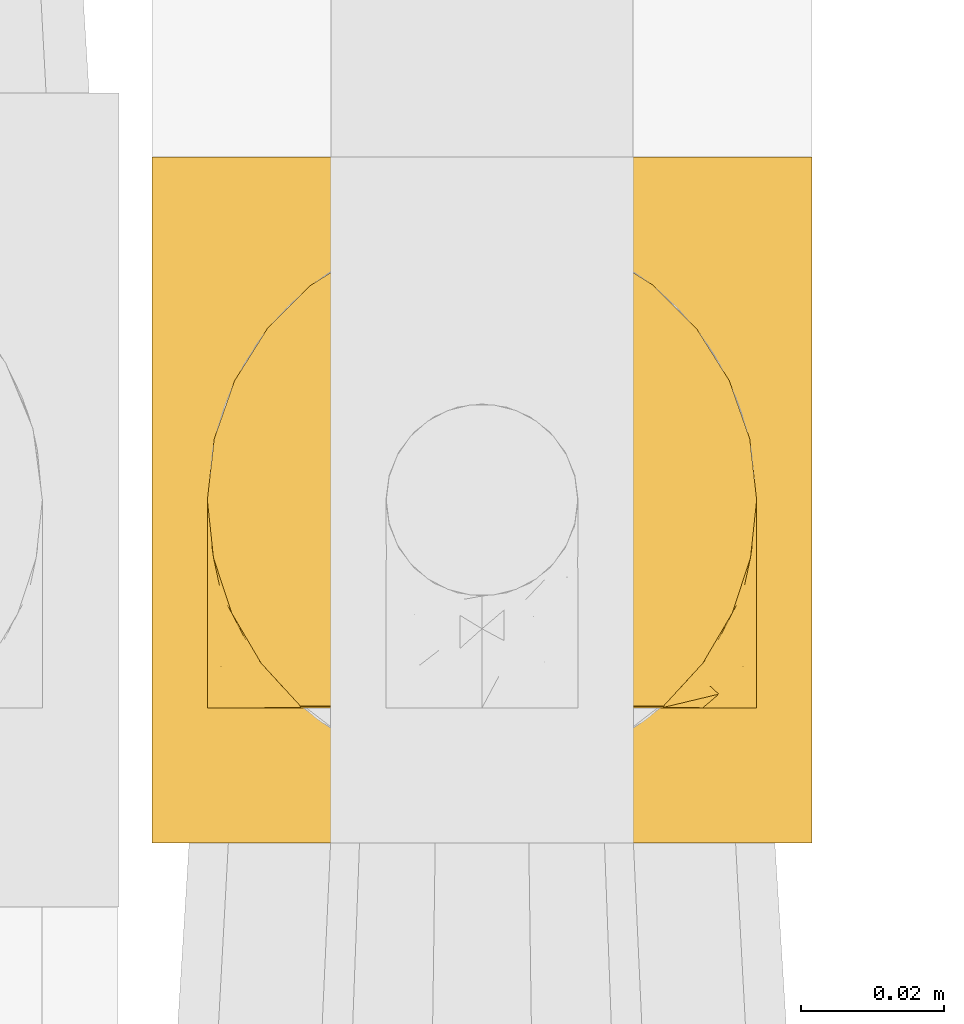
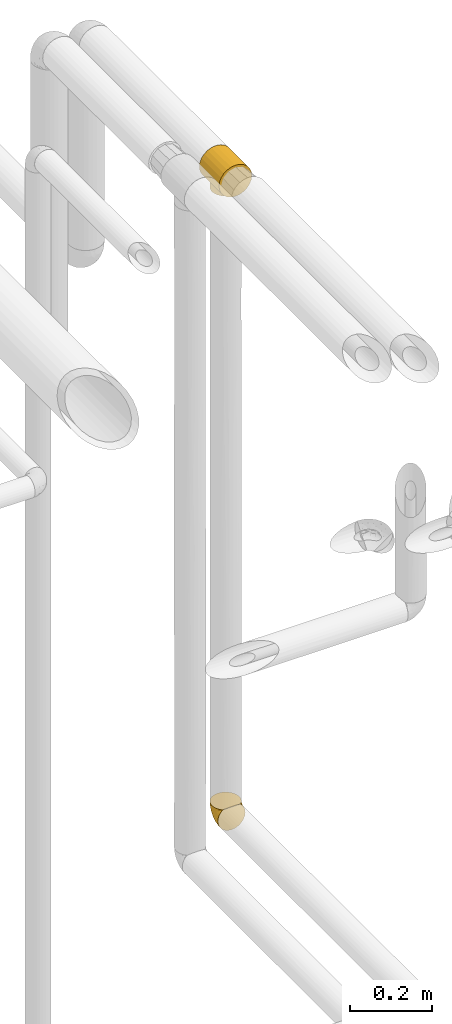
# One storey, part 508 of 827: 2 coverings.
"""IFC2X3 building model written with IfcOpenShell, lengths in millimetres."""

from ifc_helpers import new_model, entity, si_unit, converted_unit, derived_unit, direction, frame, origin, place, context, subcontext, project, spatial, faceted_brep, element, save


model = new_model("IFC2X3")

# Units and contexts
model_context = context("Model", 3, precision=0.01, world=origin(), true_north=direction((6.12303176911189e-17, 1.0)))
body_context = subcontext(model_context, "Body", "Model", "MODEL_VIEW")
ifc_project = project(units=[si_unit("LENGTHUNIT", "METRE", prefix="MILLI"), si_unit("AREAUNIT", "SQUARE_METRE"), si_unit("VOLUMEUNIT", "CUBIC_METRE"), converted_unit("PLANEANGLEUNIT", "DEGREE", entity("IfcRatioMeasure", 0.0174532925199433), si_unit("PLANEANGLEUNIT", "RADIAN"), dimensions=[0, 0, 0, 0, 0, 0, 0]), si_unit("MASSUNIT", "GRAM", prefix="KILO"), derived_unit("MASSDENSITYUNIT", [(si_unit("MASSUNIT", "GRAM", prefix="KILO"), 1), (si_unit("LENGTHUNIT", "METRE"), -3)]), derived_unit("MOMENTOFINERTIAUNIT", [(si_unit("LENGTHUNIT", "METRE"), 4)]), si_unit("TIMEUNIT", "SECOND"), si_unit("FREQUENCYUNIT", "HERTZ"), si_unit("THERMODYNAMICTEMPERATUREUNIT", "DEGREE_CELSIUS"), derived_unit("THERMALTRANSMITTANCEUNIT", [(si_unit("MASSUNIT", "GRAM", prefix="KILO"), 1), (si_unit("THERMODYNAMICTEMPERATUREUNIT", "KELVIN"), -1), (si_unit("TIMEUNIT", "SECOND"), -3)]), derived_unit("VOLUMETRICFLOWRATEUNIT", [(si_unit("LENGTHUNIT", "METRE"), 3), (si_unit("TIMEUNIT", "SECOND"), -1)]), derived_unit("MASSFLOWRATEUNIT", [(si_unit("MASSUNIT", "GRAM", prefix="KILO"), 1), (si_unit("TIMEUNIT", "SECOND"), -1)]), derived_unit("ROTATIONALFREQUENCYUNIT", [(si_unit("TIMEUNIT", "SECOND"), -1)]), si_unit("ELECTRICCURRENTUNIT", "AMPERE"), si_unit("ELECTRICVOLTAGEUNIT", "VOLT"), si_unit("POWERUNIT", "WATT"), si_unit("FORCEUNIT", "NEWTON", prefix="KILO"), si_unit("ILLUMINANCEUNIT", "LUX"), si_unit("LUMINOUSFLUXUNIT", "LUMEN"), si_unit("LUMINOUSINTENSITYUNIT", "CANDELA"), derived_unit("USERDEFINED", [(si_unit("MASSUNIT", "GRAM", prefix="KILO"), -1), (si_unit("LENGTHUNIT", "METRE"), -2), (si_unit("TIMEUNIT", "SECOND"), 3), (si_unit("LUMINOUSFLUXUNIT", "LUMEN"), 1)]), derived_unit("LINEARVELOCITYUNIT", [(si_unit("LENGTHUNIT", "METRE"), 1), (si_unit("TIMEUNIT", "SECOND"), -1)]), si_unit("PRESSUREUNIT", "PASCAL"), derived_unit("USERDEFINED", [(si_unit("LENGTHUNIT", "METRE"), -2), (si_unit("MASSUNIT", "GRAM", prefix="KILO"), 1), (si_unit("TIMEUNIT", "SECOND"), -2)]), derived_unit("LINEARFORCEUNIT", [(si_unit("MASSUNIT", "GRAM", prefix="KILO"), 1), (si_unit("LENGTHUNIT", "METRE"), 1), (si_unit("TIMEUNIT", "SECOND"), -2), (si_unit("LENGTHUNIT", "METRE"), -1)]), derived_unit("PLANARFORCEUNIT", [(si_unit("MASSUNIT", "GRAM", prefix="KILO"), 1), (si_unit("LENGTHUNIT", "METRE"), 1), (si_unit("TIMEUNIT", "SECOND"), -2), (si_unit("LENGTHUNIT", "METRE"), -2)])], contexts=[model_context])

# Site, building, storey
site_placement = place(None, origin())
site = spatial("IfcSite", under=ifc_project, at=site_placement, CompositionType="ELEMENT")
building_placement = place(site_placement, origin())
building = spatial("IfcBuilding", under=site, at=building_placement, CompositionType="ELEMENT")
storey_placement = place(building_placement, frame((0.0, 0.0, 28200.0)))
storey = spatial("IfcBuildingStorey", under=building, at=storey_placement, Name="08", CompositionType="ELEMENT", Elevation=28200.0)

# Coverings
covering_1_placement = place(storey_placement, frame((61104.84, 17404.83, 2951.74)))
element("IfcCovering", 1, at=covering_1_placement, inside=storey, Name=":ADSK_", ObjectType=":ADSK_", PredefinedType="INSULATION", context=body_context, shape_type="Brep", body=[
    faceted_brep([(24.7, 96.0, 88.01), (35.84, 96.0, 92.63), (47.8, 96.0, 94.2), (59.75, 96.0, 92.63), (70.9, 96.0, 88.01), (80.46, 96.0, 80.67), (87.81, 96.0, 71.1), (92.42, 96.0, 59.96), (94.0, 96.0, 48.0), (92.42, 96.0, 36.04), (87.81, 96.0, 24.9), (80.46, 96.0, 15.33), (75.68, 96.0, 11.66), (70.9, 96.0, 7.99), (68.11, 96.0, 6.84), (65.32, 96.0, 5.68), (62.54, 96.0, 4.53), (59.75, 96.0, 3.37), (56.76, 96.0, 2.98), (53.77, 96.0, 2.59), (50.78, 96.0, 2.19), (47.8, 96.0, 1.8), (44.81, 96.0, 2.19), (41.82, 96.0, 2.59), (38.83, 96.0, 2.98), (35.84, 96.0, 3.37), (33.05, 96.0, 4.53), (30.27, 96.0, 5.68), (27.48, 96.0, 6.84), (24.7, 96.0, 7.99), (19.91, 96.0, 11.66), (15.13, 96.0, 15.33), (7.78, 96.0, 24.9), (3.17, 96.0, 36.04), (1.6, 96.0, 48.0), (3.17, 96.0, 59.96), (7.78, 96.0, 71.1), (15.13, 96.0, 80.67), (94.0, 0.0, 48.0), (92.42, 0.0, 59.96), (87.81, 0.0, 71.1), (80.46, 0.0, 80.67), (70.9, 0.0, 88.01), (59.75, 0.0, 92.63), (47.8, 0.0, 94.2), (35.84, 0.0, 92.63), (24.7, 0.0, 88.01), (15.13, 0.0, 80.67), (7.78, 0.0, 71.1), (3.17, 0.0, 59.96), (1.6, 0.0, 48.0), (3.17, 0.0, 36.04), (7.78, 0.0, 24.9), (15.13, 0.0, 15.33), (19.91, 0.0, 11.66), (24.7, 0.0, 7.99), (27.48, 0.0, 6.84), (30.27, 0.0, 5.68), (33.05, 0.0, 4.53), (35.84, 0.0, 3.37), (38.83, 0.0, 2.98), (41.82, 0.0, 2.59), (44.81, 0.0, 2.19), (47.8, 0.0, 1.8), (50.78, 0.0, 2.19), (53.77, 0.0, 2.59), (56.76, 0.0, 2.98), (59.75, 0.0, 3.37), (62.54, 0.0, 4.53), (65.32, 0.0, 5.68), (68.11, 0.0, 6.84), (70.9, 0.0, 7.99), (75.68, 0.0, 11.66), (80.46, 0.0, 15.33), (87.81, 0.0, 24.9), (92.42, 0.0, 36.04), (86.25, 48.0, 22.39), (77.97, 24.17, 13.02), (82.31, 31.06, 17.29), (72.25, 18.33, 8.81), (65.18, 82.3, 5.19), (61.03, 83.83, 3.95), (85.18, 39.03, 20.86), (68.72, 16.02, 7.0), (52.34, 10.09, 2.25), (54.61, 10.37, 2.48), (82.31, 64.94, 17.29), (85.18, 56.97, 20.86), (50.07, 86.18, 2.03), (77.97, 71.83, 13.02), (72.25, 77.67, 8.81), (68.72, 79.98, 7.0), (65.18, 13.7, 5.19), (61.03, 12.17, 3.95), (50.07, 9.82, 2.03), (47.8, 86.45, 1.8), (47.8, 9.55, 1.8), (56.88, 10.64, 2.7), (58.95, 84.6, 3.32), (58.95, 11.4, 3.32), (52.34, 85.91, 2.25), (54.61, 85.63, 2.48), (56.88, 85.36, 2.7), (43.25, 10.09, 2.25), (36.64, 11.4, 3.32), (34.56, 12.17, 3.95), (26.87, 16.02, 7.0), (36.64, 84.6, 3.32), (38.71, 85.36, 2.7), (30.41, 13.7, 5.19), (23.34, 18.33, 8.81), (38.71, 10.64, 2.7), (40.98, 85.63, 2.48), (45.52, 86.18, 2.03), (43.25, 85.91, 2.25), (40.98, 10.37, 2.48), (26.87, 79.98, 7.0), (23.34, 77.67, 8.81), (17.62, 24.17, 13.02), (34.56, 83.83, 3.95), (17.62, 71.83, 13.02), (30.41, 82.3, 5.19), (45.52, 9.82, 2.03), (13.28, 31.06, 17.29), (9.35, 48.0, 22.39), (10.41, 39.03, 20.86), (13.28, 64.94, 17.29), (10.41, 56.97, 20.86), (86.25, 48.0, 0.0), (84.94, 38.05, 0.0), (81.09, 28.77, 0.0), (74.98, 20.81, 0.0), (67.02, 14.7, 0.0), (62.38, 12.78, 0.0), (57.75, 10.86, 0.0), (55.26, 10.53, 0.0), (52.77, 10.21, 0.0), (50.28, 9.88, 0.0), (47.8, 9.55, 0.0), (45.31, 9.88, 0.0), (42.82, 10.21, 0.0), (40.33, 10.53, 0.0), (37.84, 10.86, 0.0), (33.21, 12.78, 0.0), (28.57, 14.7, 0.0), (20.61, 20.81, 0.0), (14.5, 28.77, 0.0), (10.66, 38.05, 0.0), (9.35, 48.0, 0.0), (10.66, 57.95, 0.0), (14.5, 67.22, 0.0), (20.61, 75.19, 0.0), (28.57, 81.3, 0.0), (33.21, 83.22, 0.0), (37.84, 85.14, 0.0), (40.33, 85.47, 0.0), (42.82, 85.79, 0.0), (45.31, 86.12, 0.0), (47.8, 86.45, 0.0), (50.28, 86.12, 0.0), (52.77, 85.79, 0.0), (55.26, 85.47, 0.0), (57.75, 85.14, 0.0), (62.38, 83.22, 0.0), (67.02, 81.3, 0.0), (74.98, 75.19, 0.0), (81.09, 67.22, 0.0), (84.94, 57.95, 0.0)], [[[0, 1, 2, 3, 4, 5, 6, 7, 8, 9, 10, 11, 12, 13, 14, 15, 16, 17, 18, 19, 20, 21, 22, 23, 24, 25, 26, 27, 28, 29, 30, 31, 32, 33, 34, 35, 36, 37]], [[38, 39, 40, 41, 42, 43, 44, 45, 46, 47, 48, 49, 50, 51, 52, 53, 54, 55, 56, 57, 58, 59, 60, 61, 62, 63, 64, 65, 66, 67, 68, 69, 70, 71, 72, 73, 74, 75]], [[42, 41, 5, 4]], [[2, 44, 43, 3]], [[43, 42, 4, 3]], [[6, 40, 39, 7]], [[7, 39, 38, 8]], [[5, 41, 40, 6]], [[75, 9, 8, 38]], [[74, 76, 75]], [[73, 77, 78]], [[72, 71, 79]], [[16, 80, 81]], [[82, 74, 78]], [[77, 73, 72]], [[78, 74, 73]], [[82, 76, 74]], [[9, 76, 10]], [[83, 71, 70]], [[65, 84, 85]], [[86, 10, 87]], [[88, 21, 20]], [[11, 10, 86]], [[89, 11, 86]], [[90, 12, 89]], [[87, 10, 76]], [[75, 76, 9]], [[80, 14, 91]], [[70, 92, 83]], [[92, 68, 93]], [[79, 71, 83]], [[66, 65, 85]], [[68, 67, 93]], [[92, 70, 69, 68]], [[84, 64, 94]], [[21, 88, 95]], [[94, 63, 96]], [[80, 16, 15, 14]], [[66, 85, 97]], [[17, 81, 98]], [[63, 94, 64]], [[99, 66, 97]], [[90, 13, 12]], [[67, 99, 93]], [[91, 14, 13]], [[13, 90, 91]], [[89, 12, 11]], [[20, 19, 100]], [[101, 18, 102]], [[18, 101, 19]], [[17, 98, 18]], [[18, 98, 102]], [[66, 99, 67]], [[19, 101, 100]], [[84, 65, 64]], [[77, 72, 79]], [[20, 100, 88]], [[81, 17, 16]], [[61, 103, 62]], [[60, 59, 104]], [[105, 59, 58]], [[55, 106, 56]], [[107, 24, 108]], [[57, 56, 109, 58]], [[54, 110, 55]], [[104, 111, 60]], [[58, 109, 105]], [[24, 112, 108]], [[24, 107, 25]], [[22, 113, 114]], [[115, 60, 111]], [[116, 117, 29]], [[110, 54, 118]], [[116, 29, 28]], [[25, 119, 26]], [[120, 30, 117]], [[26, 121, 28, 27]], [[122, 63, 62]], [[109, 56, 106]], [[59, 105, 104]], [[118, 53, 123]], [[53, 118, 54]], [[123, 53, 52]], [[124, 52, 51]], [[63, 122, 96]], [[113, 21, 95]], [[124, 125, 52]], [[52, 125, 123]], [[51, 50, 34, 33]], [[114, 23, 22]], [[21, 113, 22]], [[24, 23, 112]], [[31, 126, 32]], [[28, 121, 116]], [[30, 29, 117]], [[31, 120, 126]], [[126, 127, 32]], [[25, 107, 119]], [[124, 32, 127]], [[32, 124, 33]], [[60, 115, 61]], [[33, 124, 51]], [[121, 26, 119]], [[120, 31, 30]], [[23, 114, 112]], [[55, 110, 106]], [[62, 103, 122]], [[61, 115, 103]], [[35, 49, 48, 36]], [[36, 48, 47, 37]], [[50, 49, 35, 34]], [[0, 46, 45, 1]], [[1, 45, 44, 2]], [[37, 47, 46, 0]], [[128, 129, 130, 131, 132, 133, 134, 135, 136, 137, 138, 139, 140, 141, 142, 143, 144, 145, 146, 147, 148, 149, 150, 151, 152, 153, 154, 155, 156, 157, 158, 159, 160, 161, 162, 163, 164, 165, 166, 167]], [[97, 135, 134]], [[92, 133, 132]], [[94, 138, 137]], [[137, 136, 84]], [[134, 93, 99, 97]], [[132, 79, 83, 92]], [[133, 93, 134]], [[133, 92, 93]], [[132, 131, 79]], [[137, 84, 94]], [[77, 131, 130]], [[138, 94, 96]], [[129, 128, 82]], [[85, 136, 135]], [[78, 130, 129]], [[136, 85, 84]], [[77, 130, 78]], [[82, 78, 129]], [[76, 82, 128]], [[135, 97, 85]], [[131, 77, 79]], [[87, 128, 167]], [[86, 167, 166]], [[160, 101, 161]], [[76, 128, 87]], [[102, 162, 161]], [[87, 167, 86]], [[166, 89, 86]], [[88, 158, 95]], [[166, 165, 89]], [[90, 165, 164]], [[162, 102, 98, 81]], [[159, 88, 100]], [[160, 100, 101]], [[164, 80, 91, 90]], [[80, 164, 163]], [[161, 101, 102]], [[163, 81, 80]], [[162, 81, 163]], [[158, 88, 159]], [[165, 90, 89]], [[100, 160, 159]], [[108, 155, 154]], [[121, 153, 152]], [[113, 158, 157]], [[157, 156, 114]], [[154, 119, 107, 108]], [[152, 117, 116, 121]], [[153, 119, 154]], [[153, 121, 119]], [[152, 151, 117]], [[155, 108, 112]], [[120, 151, 150]], [[150, 149, 126]], [[148, 127, 149]], [[156, 112, 114]], [[120, 150, 126]], [[157, 114, 113]], [[127, 126, 149]], [[124, 127, 148]], [[112, 156, 155]], [[151, 120, 117]], [[158, 113, 95]], [[125, 148, 147]], [[123, 147, 146]], [[140, 115, 141]], [[124, 148, 125]], [[111, 142, 141]], [[125, 147, 123]], [[146, 118, 123]], [[122, 138, 96]], [[146, 145, 118]], [[110, 145, 144]], [[142, 111, 104, 105]], [[139, 122, 103]], [[140, 103, 115]], [[144, 109, 106, 110]], [[109, 144, 143]], [[141, 115, 111]], [[143, 105, 109]], [[142, 105, 143]], [[138, 122, 139]], [[145, 110, 118]], [[103, 140, 139]]]),
])
covering_2_placement = place(storey_placement, frame((61112.59, 17422.14, 1059.95)))
element("IfcCovering", 2, at=covering_2_placement, inside=storey, Name=":ADSK_", ObjectType=":ADSK_", PredefinedType="INSULATION", context=body_context, shape_type="Brep", body=[
    faceted_brep([(74.68, 47.38, 69.15), (70.1, 54.67, 69.15), (64.01, 60.76, 69.15), (56.72, 65.34, 69.15), (48.6, 68.18, 69.15), (40.05, 69.15, 69.15), (31.49, 68.18, 69.15), (23.36, 65.33, 69.15), (16.07, 60.75, 69.15), (9.98, 54.66, 69.15), (5.4, 47.37, 69.15), (2.56, 39.25, 69.15), (1.6, 30.7, 69.15), (2.46, 22.59, 69.15), (5.01, 14.86, 69.15), (9.13, 7.84, 69.15), (14.62, 1.85, 69.15), (16.82, 1.85, 69.15), (18.56, 1.85, 69.15), (20.52, 1.85, 69.15), (22.49, 1.85, 69.15), (24.46, 1.85, 69.15), (26.42, 1.85, 69.15), (28.39, 1.85, 69.15), (30.36, 1.85, 69.15), (32.55, 1.85, 69.15), (34.75, 1.85, 69.15), (36.94, 1.85, 69.15), (39.13, 1.85, 69.15), (41.33, 1.85, 69.15), (43.52, 1.85, 69.15), (45.72, 1.85, 69.15), (47.91, 1.85, 69.15), (50.11, 1.85, 69.15), (52.3, 1.85, 69.15), (54.49, 1.85, 69.15), (56.69, 1.85, 69.15), (58.88, 1.85, 69.15), (61.08, 1.85, 69.15), (63.27, 1.85, 69.15), (65.47, 1.85, 69.15), (70.97, 7.85, 69.15), (75.09, 14.88, 69.15), (77.64, 22.61, 69.15), (78.5, 30.7, 69.15), (77.53, 39.26, 69.15), (14.62, 1.6, 68.89), (9.12, 1.6, 62.89), (5.0, 1.6, 55.87), (2.46, 1.6, 48.14), (1.6, 1.6, 40.05), (2.91, 1.6, 30.09), (6.75, 1.6, 20.82), (12.86, 1.6, 12.86), (20.82, 1.6, 6.75), (30.09, 1.6, 2.91), (40.05, 1.6, 1.6), (50.0, 1.6, 2.91), (59.27, 1.6, 6.75), (67.23, 1.6, 12.86), (73.34, 1.6, 20.82), (77.19, 1.6, 30.09), (78.5, 1.6, 40.05), (77.63, 1.6, 48.14), (75.09, 1.6, 55.87), (70.97, 1.6, 62.89), (65.47, 1.6, 68.89), (63.27, 1.6, 68.89), (62.29, 1.6, 68.89), (60.7, 1.6, 68.89), (59.11, 1.6, 68.89), (57.52, 1.6, 68.89), (55.93, 1.6, 68.89), (54.34, 1.6, 68.89), (52.76, 1.6, 68.89), (51.17, 1.6, 68.89), (49.58, 1.6, 68.89), (47.99, 1.6, 68.89), (46.4, 1.6, 68.89), (44.81, 1.6, 68.89), (43.22, 1.6, 68.89), (41.63, 1.6, 68.89), (40.05, 1.6, 68.89), (38.46, 1.6, 68.89), (36.87, 1.6, 68.89), (35.28, 1.6, 68.89), (33.69, 1.6, 68.89), (32.1, 1.6, 68.89), (30.51, 1.6, 68.89), (28.92, 1.6, 68.89), (27.33, 1.6, 68.89), (25.37, 1.6, 68.89), (23.4, 1.6, 68.89), (21.21, 1.6, 68.89), (19.01, 1.6, 68.89), (16.82, 1.6, 68.89), (42.32, 1.78, 68.97), (44.02, 1.77, 68.96), (47.13, 1.78, 68.97), (48.74, 1.77, 68.97), (23.57, 1.79, 68.98), (25.13, 1.78, 68.97), (61.34, 1.76, 68.96), (22.02, 1.77, 68.96), (29.72, 1.77, 68.96), (56.73, 1.76, 68.96), (55.14, 1.77, 68.96), (37.66, 1.77, 68.96), (64.12, 1.8, 69.0), (28.13, 1.76, 68.96), (26.62, 1.77, 68.96), (31.46, 1.78, 68.97), (16.16, 1.77, 68.96), (39.16, 1.77, 68.96), (50.37, 1.76, 68.96), (17.69, 1.77, 68.97), (19.17, 1.78, 68.97), (62.78, 1.77, 68.97), (58.35, 1.77, 68.96), (45.53, 1.77, 68.96), (59.91, 1.78, 68.97), (65.47, 1.77, 68.97), (65.47, 1.8, 69.02), (65.47, 1.82, 69.08), (14.62, 1.77, 68.97), (14.62, 1.72, 68.94), (14.62, 1.66, 68.92), (20.59, 1.76, 68.96), (32.99, 1.77, 68.96), (34.48, 1.76, 68.95), (51.91, 1.77, 68.96), (65.47, 1.66, 68.92), (65.47, 1.72, 68.94), (53.48, 1.78, 68.98), (14.62, 1.82, 69.08), (14.62, 1.8, 69.02), (40.77, 1.77, 68.96), (35.97, 1.78, 68.97), (7.84, 3.72, 61.33), (3.53, 7.41, 53.1), (8.32, 6.13, 63.33), (1.6, 21.47, 49.27), (2.19, 19.34, 55.53), (1.6, 26.8, 54.6), (1.6, 8.87, 41.99), (4.57, 9.2, 57.07), (3.96, 12.79, 57.95), (2.28, 14.62, 51.56), (1.6, 7.34, 41.58), (7.69, 5.33, 61.7), (3.53, 17.64, 63.33), (8.32, 7.7, 65.0), (7.84, 9.41, 67.02), (1.6, 28.75, 61.87), (1.6, 16.15, 43.94), (4.34, 14.14, 61.21), (1.6, 29.16, 63.4), (29.63, 57.02, 33.11), (27.34, 64.92, 52.82), (40.05, 64.0, 43.3), (2.39, 11.92, 33.73), (2.43, 19.16, 36.52), (9.07, 28.65, 24.87), (16.64, 24.62, 14.17), (9.54, 15.19, 18.43), (4.52, 18.36, 28.67), (4.52, 9.2, 26.0), (7.49, 46.98, 49.25), (7.49, 50.24, 59.72), (12.85, 56.1, 55.1), (2.35, 28.97, 44.72), (22.66, 54.46, 34.15), (32.9, 21.34, 5.25), (25.33, 18.4, 6.75), (40.05, 66.44, 55.54), (16.64, 12.07, 10.47), (19.99, 45.49, 25.49), (16.37, 50.57, 35.53), (3.26, 36.04, 48.22), (3.75, 42.07, 58.71), (19.58, 62.12, 57.42), (7.5, 37.37, 34.84), (4.04, 29.39, 36.87), (13.94, 53.59, 45.01), (19.58, 58.06, 44.4), (28.21, 49.27, 23.96), (24.75, 29.63, 11.2), (31.42, 33.21, 10.56), (26.2, 40.1, 16.81), (33.36, 44.08, 17.38), (40.05, 49.36, 21.38), (40.05, 56.68, 32.34), (40.05, 15.2, 4.3), (16.14, 35.57, 20.65), (12.85, 41.7, 29.66), (10.47, 46.4, 39.6), (6.49, 41.41, 42.55), (40.05, 27.45, 6.74), (40.05, 38.4, 14.06), (75.57, 12.99, 26.84), (47.37, 21.33, 5.28), (52.91, 42.89, 18.52), (50.46, 57.04, 33.13), (67.23, 56.11, 55.1), (60.5, 62.13, 57.43), (70.55, 21.89, 20.72), (63.45, 16.62, 11.46), (62.61, 32.9, 17.69), (72.6, 46.99, 49.26), (72.6, 50.25, 59.73), (76.34, 42.08, 58.71), (59.34, 49.91, 29.72), (77.76, 15.6, 35.35), (78.5, 16.15, 43.94), (78.5, 8.87, 41.99), (78.5, 29.16, 63.4), (53.16, 13.16, 4.93), (70.55, 10.83, 17.46), (48.88, 33.8, 10.94), (54.76, 25.02, 8.92), (52.74, 64.92, 52.83), (71.93, 32.83, 29.34), (75.79, 20.56, 30.26), (60.5, 58.07, 44.4), (77.86, 21.46, 39.06), (77.64, 28.1, 43.06), (78.5, 26.8, 54.6), (78.5, 21.47, 49.27), (67.23, 51.29, 42.69), (76.82, 36.04, 48.2), (78.5, 28.75, 61.87), (77.8, 8.45, 33.44), (67.23, 41.73, 29.67), (73.2, 39.27, 38.5), (67.66, 33.56, 23.35), (75.99, 27.29, 34.97), (76.57, 7.41, 53.1), (73.21, 3.51, 59.68), (71.93, 4.68, 62.19), (71.07, 5.52, 64.11), (75.09, 8.75, 57.97), (76.13, 12.79, 57.95), (76.57, 17.65, 63.33), (77.69, 13.9, 51.77), (72.26, 9.42, 67.02), (71.77, 7.68, 64.98), (77.9, 19.33, 55.53), (75.75, 14.13, 61.22)], [[[0, 1, 2, 3, 4, 5, 6, 7, 8, 9, 10, 11, 12, 13, 14, 15, 16, 17, 18, 19, 20, 21, 22, 23, 24, 25, 26, 27, 28, 29, 30, 31, 32, 33, 34, 35, 36, 37, 38, 39, 40, 41, 42, 43, 44, 45]], [[46, 47, 48, 49, 50, 51, 52, 53, 54, 55, 56, 57, 58, 59, 60, 61, 62, 63, 64, 65, 66, 67, 68, 69, 70, 71, 72, 73, 74, 75, 76, 77, 78, 79, 80, 81, 82, 83, 84, 85, 86, 87, 88, 89, 90, 91, 92, 93, 94, 95]], [[96, 97, 30]], [[98, 77, 99]], [[100, 101, 21]], [[69, 68, 102]], [[20, 19, 103]], [[24, 23, 104]], [[20, 103, 100]], [[72, 105, 106]], [[84, 83, 107]], [[89, 88, 104]], [[108, 67, 66]], [[109, 110, 90]], [[111, 25, 24]], [[112, 17, 16]], [[82, 113, 83]], [[109, 23, 22]], [[114, 76, 75]], [[105, 36, 106]], [[104, 111, 24]], [[18, 115, 116]], [[97, 96, 80]], [[67, 108, 117]], [[105, 71, 118]], [[31, 97, 119]], [[102, 120, 69]], [[108, 121, 122, 123, 40]], [[112, 95, 115]], [[17, 115, 18]], [[94, 116, 115]], [[117, 68, 67]], [[38, 117, 39]], [[112, 124, 125, 126, 46]], [[17, 112, 115]], [[70, 120, 118]], [[39, 117, 108]], [[120, 38, 37]], [[120, 37, 118]], [[120, 70, 69]], [[116, 94, 127]], [[128, 86, 129]], [[117, 38, 102]], [[74, 130, 75]], [[99, 33, 32]], [[115, 95, 94]], [[39, 108, 40]], [[108, 66, 131, 132, 121]], [[105, 72, 71]], [[118, 37, 36]], [[71, 70, 118]], [[35, 106, 36]], [[36, 105, 118]], [[35, 133, 106]], [[74, 73, 133]], [[106, 133, 73]], [[99, 114, 33]], [[133, 35, 34]], [[73, 72, 106]], [[95, 112, 46]], [[112, 16, 134, 135, 124]], [[130, 114, 75]], [[99, 76, 114]], [[114, 130, 33]], [[34, 33, 130]], [[78, 77, 98]], [[98, 119, 78]], [[130, 133, 34]], [[133, 130, 74]], [[79, 97, 80]], [[98, 99, 32]], [[98, 32, 31]], [[77, 76, 99]], [[97, 79, 119]], [[136, 96, 29]], [[30, 97, 31]], [[136, 29, 28]], [[81, 80, 96]], [[29, 96, 30]], [[31, 119, 98]], [[119, 79, 78]], [[96, 136, 81]], [[82, 81, 136]], [[113, 107, 83]], [[84, 107, 137]], [[107, 27, 137]], [[113, 28, 107]], [[27, 107, 28]], [[85, 84, 137]], [[137, 27, 26]], [[113, 136, 28]], [[136, 113, 82]], [[109, 89, 104]], [[86, 85, 129]], [[89, 109, 90]], [[111, 87, 128]], [[26, 129, 137]], [[88, 111, 104]], [[25, 111, 128]], [[22, 110, 109]], [[23, 109, 104]], [[110, 91, 90]], [[100, 92, 101]], [[110, 22, 101]], [[91, 110, 101]], [[116, 19, 18]], [[111, 88, 87]], [[127, 103, 19]], [[25, 128, 26]], [[86, 128, 87]], [[128, 129, 26]], [[137, 129, 85]], [[120, 102, 38]], [[117, 102, 68]], [[91, 101, 92]], [[21, 101, 22]], [[93, 92, 103]], [[100, 21, 20]], [[100, 103, 92]], [[127, 93, 103]], [[93, 127, 94]], [[116, 127, 19]], [[126, 138, 47]], [[48, 138, 139]], [[140, 125, 124]], [[141, 142, 143]], [[144, 49, 139]], [[145, 140, 146]], [[48, 139, 49]], [[139, 145, 147]], [[49, 144, 148, 50]], [[126, 125, 149]], [[14, 13, 150]], [[151, 146, 140]], [[149, 140, 145]], [[152, 151, 135]], [[152, 14, 150]], [[16, 15, 134]], [[13, 153, 150]], [[124, 151, 140]], [[141, 147, 142]], [[14, 152, 15]], [[15, 152, 134]], [[47, 46, 126]], [[139, 154, 144]], [[138, 48, 47]], [[125, 140, 149]], [[135, 134, 152]], [[146, 155, 142]], [[145, 146, 147]], [[149, 139, 138]], [[147, 141, 154]], [[147, 146, 142]], [[139, 147, 154]], [[139, 149, 145]], [[149, 138, 126]], [[155, 146, 151]], [[150, 143, 142]], [[152, 155, 151]], [[150, 142, 155]], [[13, 12, 156, 153]], [[153, 143, 150]], [[152, 150, 155]], [[151, 124, 135]], [[157, 158, 159]], [[160, 154, 161]], [[162, 163, 164]], [[165, 166, 160]], [[167, 168, 169]], [[141, 170, 161]], [[156, 12, 11]], [[158, 157, 171]], [[172, 55, 173]], [[158, 6, 174]], [[175, 54, 53]], [[52, 166, 164]], [[52, 164, 53]], [[54, 175, 173]], [[166, 52, 51]], [[176, 177, 171]], [[178, 143, 179]], [[156, 11, 179]], [[8, 7, 180]], [[169, 9, 8]], [[179, 143, 153, 156]], [[179, 11, 10]], [[168, 179, 10]], [[181, 162, 182]], [[179, 167, 178]], [[183, 184, 177]], [[183, 169, 184]], [[176, 171, 185]], [[172, 186, 187]], [[158, 7, 6]], [[159, 158, 174]], [[184, 180, 158]], [[54, 173, 55]], [[180, 169, 8]], [[188, 189, 187]], [[9, 168, 10]], [[186, 188, 187]], [[190, 157, 159, 191]], [[55, 172, 192]], [[176, 193, 194]], [[161, 170, 182]], [[162, 164, 165]], [[175, 164, 163]], [[51, 50, 148]], [[167, 195, 196]], [[178, 182, 170]], [[6, 5, 174]], [[158, 180, 7]], [[169, 180, 184]], [[169, 168, 9]], [[179, 168, 167]], [[182, 162, 165]], [[162, 194, 193]], [[161, 165, 160]], [[195, 181, 196]], [[192, 172, 197]], [[192, 56, 55]], [[189, 190, 198]], [[198, 197, 187]], [[172, 187, 197]], [[185, 189, 188]], [[198, 187, 189]], [[186, 172, 173]], [[173, 163, 186]], [[193, 186, 163]], [[176, 185, 188]], [[185, 157, 190]], [[188, 186, 193]], [[177, 176, 194]], [[188, 193, 176]], [[162, 193, 163]], [[195, 177, 194]], [[171, 177, 184]], [[181, 195, 194]], [[183, 167, 169]], [[162, 181, 194]], [[196, 182, 178]], [[158, 171, 184]], [[171, 157, 185]], [[177, 195, 183]], [[167, 183, 195]], [[182, 196, 181]], [[178, 170, 143]], [[178, 167, 196]], [[164, 175, 53]], [[173, 175, 163]], [[160, 51, 148]], [[164, 166, 165]], [[51, 160, 166]], [[160, 148, 144, 154]], [[141, 161, 154]], [[182, 165, 161]], [[190, 189, 185]], [[143, 170, 141]], [[60, 199, 61]], [[197, 200, 192]], [[201, 190, 202]], [[200, 57, 192]], [[203, 204, 2]], [[205, 206, 207]], [[208, 209, 210]], [[211, 207, 201]], [[212, 213, 214]], [[45, 215, 210]], [[216, 206, 58]], [[45, 44, 215]], [[59, 217, 60]], [[60, 217, 199]], [[0, 45, 210]], [[218, 201, 219]], [[202, 159, 220]], [[205, 221, 222]], [[223, 204, 203]], [[1, 203, 2]], [[57, 200, 216]], [[220, 3, 204]], [[220, 174, 4]], [[1, 0, 209]], [[212, 224, 213]], [[225, 226, 227]], [[228, 223, 203]], [[208, 210, 229]], [[210, 226, 229]], [[3, 220, 4]], [[58, 206, 59]], [[209, 203, 1]], [[202, 220, 223]], [[228, 203, 208]], [[202, 211, 201]], [[3, 2, 204]], [[202, 190, 191, 159]], [[210, 215, 230, 226]], [[199, 212, 231]], [[232, 233, 221]], [[233, 208, 229]], [[207, 206, 219]], [[217, 206, 205]], [[227, 224, 225]], [[233, 232, 228]], [[201, 207, 219]], [[234, 232, 221]], [[218, 219, 200]], [[202, 223, 211]], [[174, 220, 159]], [[174, 5, 4]], [[61, 231, 62]], [[220, 204, 223]], [[210, 209, 0]], [[203, 209, 208]], [[225, 233, 229]], [[224, 227, 213]], [[221, 233, 235]], [[57, 56, 192]], [[198, 218, 197]], [[200, 219, 216]], [[201, 198, 190]], [[197, 218, 200]], [[198, 201, 218]], [[206, 216, 219]], [[58, 57, 216]], [[231, 212, 214]], [[222, 212, 199]], [[228, 211, 223]], [[207, 211, 232]], [[62, 231, 214]], [[199, 231, 61]], [[233, 228, 208]], [[211, 228, 232]], [[222, 221, 235]], [[234, 205, 207]], [[206, 217, 59]], [[199, 217, 205]], [[205, 222, 199]], [[224, 222, 235]], [[222, 224, 212]], [[224, 235, 225]], [[233, 225, 235]], [[226, 225, 229]], [[205, 234, 221]], [[207, 232, 234]], [[63, 214, 236]], [[214, 213, 236]], [[214, 63, 62]], [[237, 236, 238]], [[238, 132, 131]], [[236, 237, 64]], [[239, 240, 241]], [[63, 236, 64]], [[131, 66, 65]], [[237, 131, 65]], [[242, 230, 43]], [[237, 65, 64]], [[239, 121, 132]], [[42, 242, 43]], [[241, 240, 243]], [[41, 123, 244]], [[43, 230, 215, 44]], [[244, 122, 245]], [[227, 246, 243]], [[241, 247, 245]], [[121, 239, 245]], [[41, 40, 123]], [[132, 238, 239]], [[244, 42, 41]], [[131, 237, 238]], [[240, 239, 238]], [[245, 239, 241]], [[247, 241, 246]], [[247, 244, 245]], [[238, 236, 240]], [[243, 236, 213]], [[236, 243, 240]], [[227, 226, 246]], [[243, 213, 227]], [[242, 246, 226]], [[243, 246, 241]], [[246, 242, 247]], [[244, 247, 242]], [[242, 226, 230]], [[42, 244, 242]], [[122, 244, 123]], [[122, 121, 245]]]),
])

save(model, "model.ifc")
